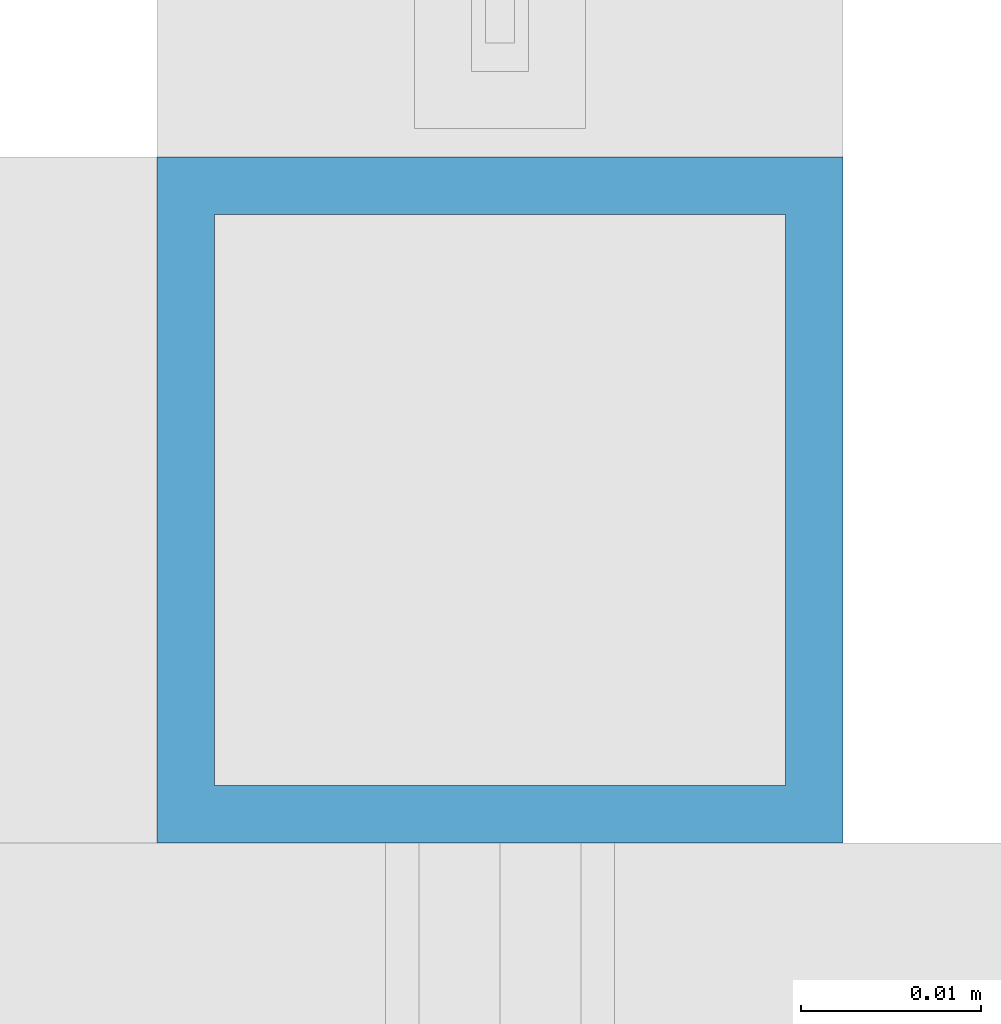
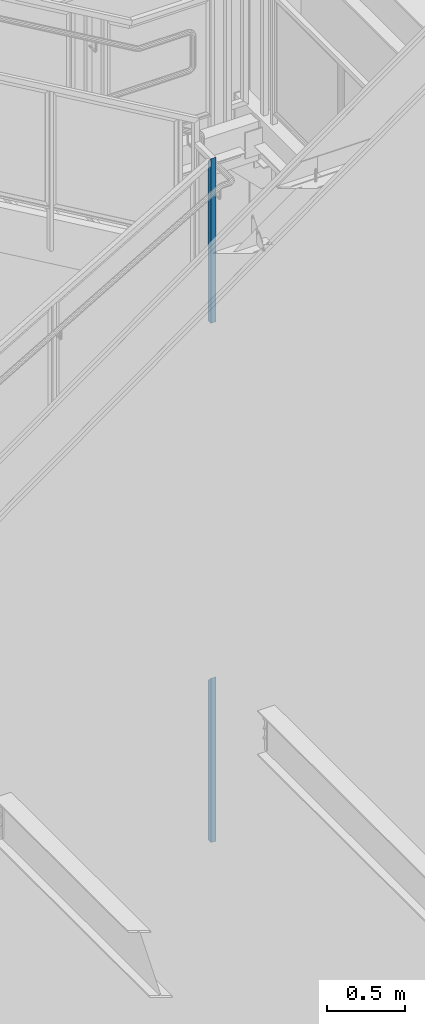
# One storey, part 375 of 1179: 2 columns, 2 elements without a shape of their own.
"""IFC2X3 building model written with IfcOpenShell, lengths in millimetres."""

from ifc_helpers import new_model, si_unit, frame, origin_with_axes, place, context, subcontext, project, spatial, faceted_brep, material, type_object, element, aggregate, save


model = new_model("IFC2X3")

# Units and contexts
model_context = context("Model", 3, precision=1e-05, world=origin_with_axes())
body_context = subcontext(model_context, "Body", "Model", "MODEL_VIEW")
ifc_project = project(units=[si_unit("LENGTHUNIT", "METRE", prefix="MILLI"), si_unit("AREAUNIT", "SQUARE_METRE"), si_unit("VOLUMEUNIT", "CUBIC_METRE"), si_unit("MASSUNIT", "GRAM", prefix="KILO"), si_unit("TIMEUNIT", "SECOND"), si_unit("PLANEANGLEUNIT", "RADIAN"), si_unit("SOLIDANGLEUNIT", "STERADIAN"), si_unit("THERMODYNAMICTEMPERATUREUNIT", "DEGREE_CELSIUS"), si_unit("LUMINOUSINTENSITYUNIT", "LUMEN")], contexts=[model_context])

# Site, building, storey
site_placement = place(None, origin_with_axes())
site = spatial("IfcSite", under=ifc_project, at=site_placement, CompositionType="ELEMENT")
building_placement = place(site_placement, origin_with_axes())
building = spatial("IfcBuilding", under=site, at=building_placement, Name="Undefined", CompositionType="ELEMENT")
storey_placement = place(building_placement, origin_with_axes())
storey = spatial("IfcBuildingStorey", under=building, at=storey_placement, Name="Undefined", CompositionType="ELEMENT", Elevation=0.0)

# Assembly, column
assembly_1_placement = place(storey_placement, origin_with_axes())
assembly_1 = element("IfcElementAssembly", 1, at=assembly_1_placement, inside=storey, Name="GUARDRAIL", AssemblyPlace="NOTDEFINED", PredefinedType="RIGID_FRAME")
ifc_material = material()
column_type = type_object("IfcColumnType", Name="HSS1-1/2X1-1/2X1/8", PredefinedType="NOTDEFINED")
column_1_placement = place(assembly_1_placement, frame((22844.1250009048, 39471.5999992249, 5979.85403868338), z_axis=(-1.0, 0.0, 0.0), x_axis=(0.0, 0.0, 1.0)))
column_1 = element("IfcColumn", 2, at=column_1_placement, type_object=column_type, material=ifc_material, Name="POST", ObjectType="HSS1-1/2X1-1/2X1/8", context=body_context, shape_type="Brep", body=[
    faceted_brep([(6.35000000000014, 15.874999282998, -15.8749992830017), (6.35000000000014, -15.874999282998, -15.8749992830017), (1294.07095975316, -15.874999282998, -15.8749992830017), (1262.32096118716, 15.874999282998, -15.8749992830017), (6.35000000000014, -15.874999282998, 15.8749992830017), (1294.07095975316, -15.874999282998, 15.8749992830017), (6.35000000000014, 15.874999282998, 15.8749992830017), (1262.32096118716, 15.874999282998, 15.8749992830017), (6.35000000000014, 19.0499992350015, -19.0499992350015), (6.35000000000014, 19.0499992350015, 19.0499992350015), (1259.14596123516, 19.0499992350015, 19.0499992350015), (1259.14596123516, 19.0499992350015, -19.0499992350015), (6.35000000000014, -19.0499992350015, 19.0499992350015), (1297.24595970516, -19.0499992350015, 19.0499992350015), (6.35000000000014, -19.0499992350015, -19.0499992350015), (1297.24595970516, -19.0499992350015, -19.0499992350015)], [[[0, 1, 2, 3]], [[1, 4, 5, 2]], [[4, 6, 7, 5]], [[6, 0, 3, 7]], [[8, 9, 10, 11]], [[9, 12, 13, 10]], [[12, 14, 15, 13]], [[14, 8, 11, 15]], [[13, 15, 11, 10], [5, 7, 3, 2]], [[14, 12, 9, 8], [6, 4, 1, 0]]]),
])
aggregate(assembly_1, [column_1])

assembly_2_placement = place(storey_placement, origin_with_axes())
assembly_2 = element("IfcElementAssembly", 3, at=assembly_2_placement, inside=storey, Name="GUARDRAIL", AssemblyPlace="NOTDEFINED", PredefinedType="RIGID_FRAME")
column_2_placement = place(assembly_2_placement, frame((22844.1248872972, 39471.5999999818, 1906.75806982366), z_axis=(-1.0, 0.0, 0.0), x_axis=(0.0, 0.0, 1.0)))
column_2 = element("IfcColumn", 4, at=column_2_placement, type_object=column_type, material=ifc_material, Name="POST", ObjectType="HSS1-1/2X1-1/2X1/8", context=body_context, shape_type="Brep", body=[
    faceted_brep([(6.35000000000014, 15.874999282998, -15.8749992830017), (6.35000000000014, -15.874999282998, -15.8749992830017), (1293.64192945934, -15.874999282998, -15.8749992830017), (1261.89193089334, 15.874999282998, -15.8749992830017), (6.35000000000014, -15.874999282998, 15.8749992830017), (1293.64192945934, -15.874999282998, 15.8749992830017), (6.35000000000014, 15.874999282998, 15.8749992830017), (1261.89193089334, 15.874999282998, 15.8749992830017), (6.35000000000014, 19.0499992350015, -19.0499992350015), (6.35000000000014, 19.0499992350015, 19.0499992350015), (1258.71693094134, 19.0499992350015, 19.0499992350015), (1258.71693094134, 19.0499992350015, -19.0499992350015), (6.35000000000014, -19.0499992350015, 19.0499992350015), (1296.81692941134, -19.0499992350015, 19.0499992350015), (6.35000000000014, -19.0499992350015, -19.0499992350015), (1296.81692941134, -19.0499992350015, -19.0499992350015)], [[[0, 1, 2, 3]], [[1, 4, 5, 2]], [[4, 6, 7, 5]], [[6, 0, 3, 7]], [[8, 9, 10, 11]], [[9, 12, 13, 10]], [[12, 14, 15, 13]], [[14, 8, 11, 15]], [[13, 15, 11, 10], [5, 7, 3, 2]], [[14, 12, 9, 8], [6, 4, 1, 0]]]),
])
aggregate(assembly_2, [column_2])

save(model, "model.ifc")
